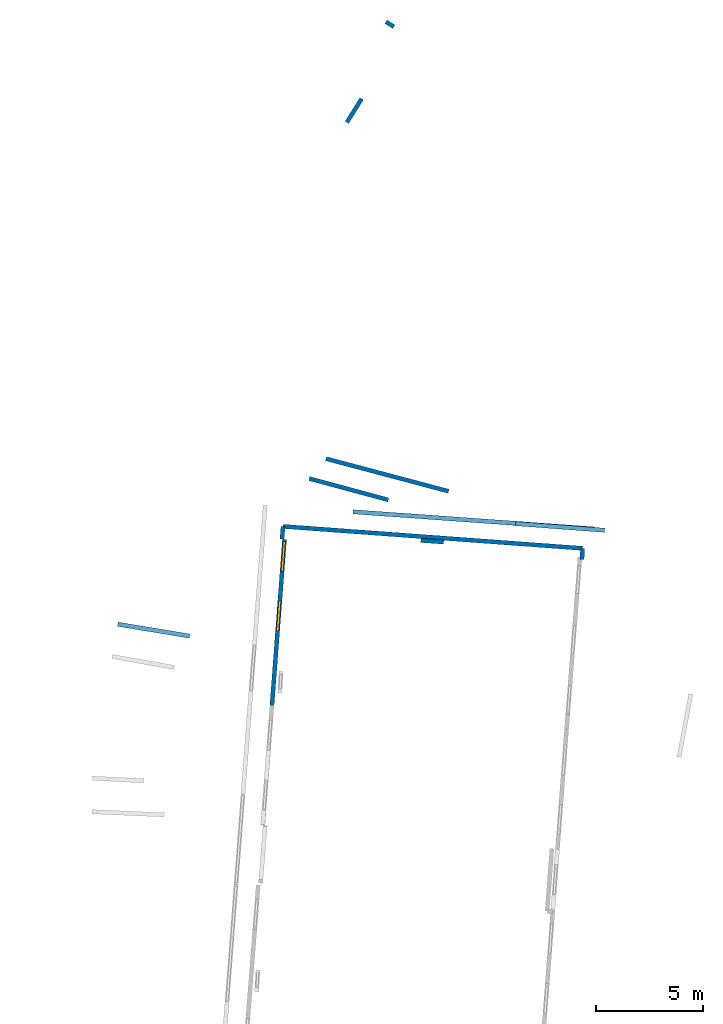
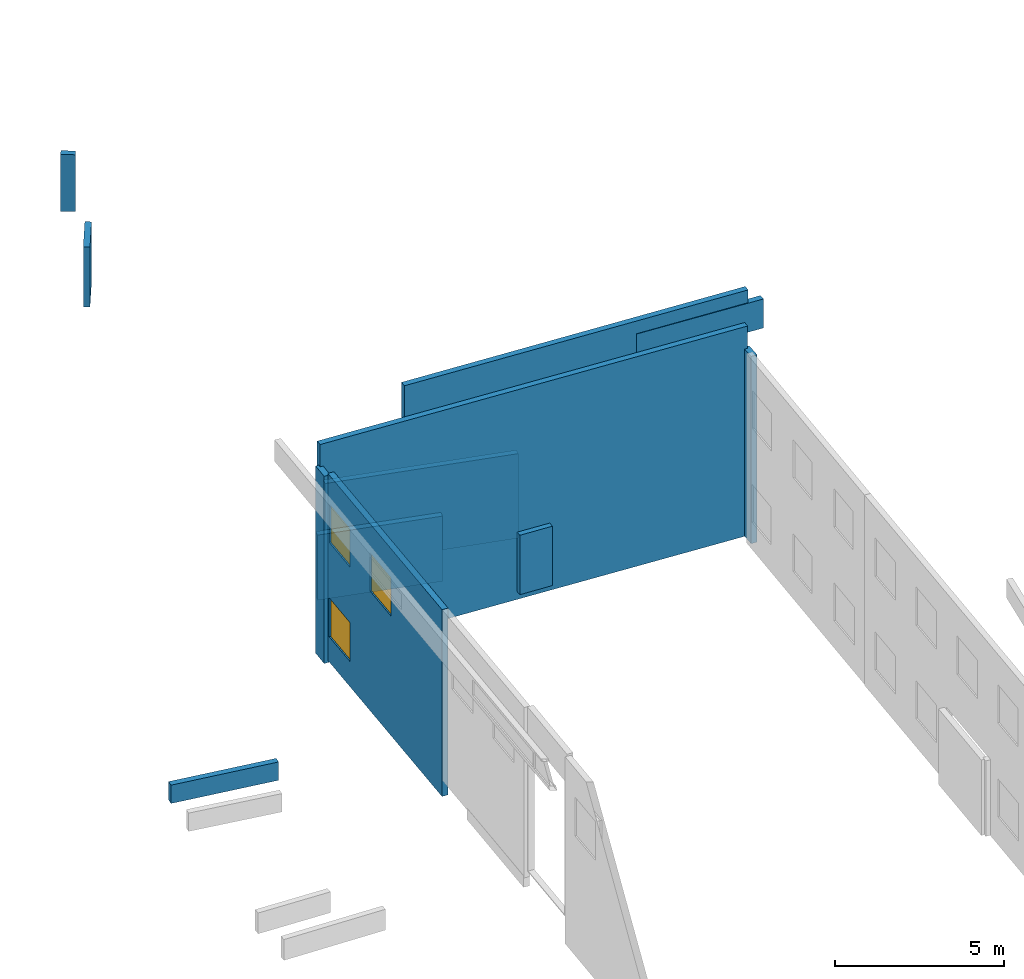
# One storey, part 25 of 27: 12 walls, 3 windows, 3 openings.
"""IFC2X3 building model written with IfcOpenShell, lengths in metres."""

from ifc_helpers import new_model, entity, si_unit, converted_unit, derived_unit, direction, frame, frame_2d, origin, origin_2d_with_axis, place, context, subcontext, project, spatial, polyline, rectangle, outline, extrude, source, transform, mapped, material, layer, layer_set, layer_usage, type_object, type_shapes, element, fill, save


model = new_model("IFC2X3")

# Units and contexts
model_context = context("Model", 3, precision=1e-05, world=origin(), true_north=direction((0.0, 1.0)))
body_context = subcontext(model_context, "Body", "Model", "MODEL_VIEW")
ifc_project = project(units=[si_unit("LENGTHUNIT", "METRE"), si_unit("AREAUNIT", "SQUARE_METRE"), si_unit("VOLUMEUNIT", "CUBIC_METRE"), converted_unit("PLANEANGLEUNIT", "DEGREE", entity("IfcRatioMeasure", 0.0174532925199433), si_unit("PLANEANGLEUNIT", "RADIAN"), dimensions=[0, 0, 0, 0, 0, 0, 0]), si_unit("MASSUNIT", "GRAM", prefix="KILO"), derived_unit("MASSDENSITYUNIT", [(si_unit("MASSUNIT", "GRAM", prefix="KILO"), 1), (si_unit("LENGTHUNIT", "METRE"), -3)]), derived_unit("MOMENTOFINERTIAUNIT", [(si_unit("LENGTHUNIT", "METRE"), 4)]), si_unit("TIMEUNIT", "SECOND"), si_unit("FREQUENCYUNIT", "HERTZ"), si_unit("THERMODYNAMICTEMPERATUREUNIT", "DEGREE_CELSIUS"), derived_unit("THERMALTRANSMITTANCEUNIT", [(si_unit("MASSUNIT", "GRAM", prefix="KILO"), 1), (si_unit("THERMODYNAMICTEMPERATUREUNIT", "KELVIN"), -1), (si_unit("TIMEUNIT", "SECOND"), -3)]), derived_unit("VOLUMETRICFLOWRATEUNIT", [(si_unit("LENGTHUNIT", "METRE"), 3), (si_unit("TIMEUNIT", "SECOND"), -1)]), si_unit("ELECTRICCURRENTUNIT", "AMPERE"), si_unit("ELECTRICVOLTAGEUNIT", "VOLT"), si_unit("POWERUNIT", "WATT"), si_unit("FORCEUNIT", "NEWTON", prefix="KILO"), si_unit("ILLUMINANCEUNIT", "LUX"), si_unit("LUMINOUSFLUXUNIT", "LUMEN"), si_unit("LUMINOUSINTENSITYUNIT", "CANDELA"), derived_unit("USERDEFINED", [(si_unit("MASSUNIT", "GRAM", prefix="KILO"), -1), (si_unit("LENGTHUNIT", "METRE"), -2), (si_unit("TIMEUNIT", "SECOND"), 3), (si_unit("LUMINOUSFLUXUNIT", "LUMEN"), 1)]), derived_unit("LINEARVELOCITYUNIT", [(si_unit("LENGTHUNIT", "METRE"), 1), (si_unit("TIMEUNIT", "SECOND"), -1)]), si_unit("PRESSUREUNIT", "PASCAL"), derived_unit("USERDEFINED", [(si_unit("LENGTHUNIT", "METRE"), -2), (si_unit("MASSUNIT", "GRAM", prefix="KILO"), 1), (si_unit("TIMEUNIT", "SECOND"), -2)]), derived_unit("LINEARFORCEUNIT", [(si_unit("MASSUNIT", "GRAM", prefix="KILO"), 1), (si_unit("LENGTHUNIT", "METRE"), 1), (si_unit("TIMEUNIT", "SECOND"), -2), (si_unit("LENGTHUNIT", "METRE"), -1)]), derived_unit("PLANARFORCEUNIT", [(si_unit("MASSUNIT", "GRAM", prefix="KILO"), 1), (si_unit("LENGTHUNIT", "METRE"), 1), (si_unit("TIMEUNIT", "SECOND"), -2), (si_unit("LENGTHUNIT", "METRE"), -2)])], contexts=[model_context])

# Site, building, storey
placement_1 = place(None, origin())
site = spatial("IfcSite", under=ifc_project, at=placement_1, CompositionType="ELEMENT")
building = spatial("IfcBuilding", under=site, at=placement_1, CompositionType="ELEMENT")
storey_placement = place(placement_1, frame((0.0, 0.0, -61.043098449707)))
storey = spatial("IfcBuildingStorey", under=building, at=storey_placement, Name="level_-61.043098", CompositionType="ELEMENT", Elevation=-61.043098449707)

# Wall
ifc_material_1 = material(Name="Default wall")
ifc_layer = layer(ifc_material_1, 0.2)
ifc_layer_set = layer_set([ifc_layer], Name="wall_thickness_0.2000")
ifc_layer_usage = layer_usage(ifc_layer_set, "AXIS2", "POSITIVE", -0.1)
wall_type = type_object("IfcWallType", Name="wall_thickness_0.2000", PredefinedType="STANDARD", material=ifc_layer_set)
placement_2 = place(placement_1, frame((0.0, 0.0, -54.1657218933105)))
wall_1_placement = place(placement_2, frame((-78.5167072208766, 36.7936952621983, 0.0), z_axis=(0.0, 0.0, 1.0), x_axis=(0.997484238293921, -0.0708886052563871, 0.0)))
element("IfcWallStandardCase", 1, at=wall_1_placement, inside=storey, type_object=wall_type, material=ifc_layer_usage, Name="Wall:413", ObjectType="Wall", context=body_context, shape_type="SweptSolid", body=[
    extrude(outline(polyline([(11.3100008133286, -0.1), (11.3100008133286, 0.1), (0.0, 0.1), (0.0, -0.1), (11.3100008133286, -0.1)])), origin(), (0.0, 0.0, 1.0), 1.25223541259766),
])

# Wall, openings, windows
placement_3 = place(placement_1, frame((0.0, 0.0, -60.9578857421875)))
wall_2_placement = place(placement_3, frame((-81.7229780345346, 35.5088413263071, 0.0), z_axis=(0.0, 0.0, 1.0), x_axis=(-0.075466794937005, -0.997148315378377, 0.0)))
wall_2 = element("IfcWallStandardCase", 2, at=wall_2_placement, inside=storey, type_object=wall_type, material=ifc_layer_usage, Name="Wall:613", ObjectType="Wall", context=body_context, shape_type="SweptSolid", body=[
    extrude(outline(polyline([(7.80127853958035, -0.1), (7.80127853958035, 0.1), (0.0, 0.1), (0.0, -0.1), (7.80127853958035, -0.1)])), origin(), (0.0, 0.0, 1.0), 6.74871063232422),
])
opening_1_placement = place(wall_2_placement, frame((0.0997649139313766, -0.1, 4.31856918334961)))
opening_1 = element("IfcOpeningElement", 3, at=opening_1_placement, cuts=wall_2, Name="Opening : 1400 x 1395 : 45", ObjectType="Opening", context=body_context, shape_type="SweptSolid", body=[
    extrude(rectangle(XDim=1.4, YDim=1.395, at=frame_2d((0.6975, 0.7), x_axis=(0.0, 1.0))), frame((0.0, 0.0, 0.0), z_axis=(0.0, 1.0, 0.0), x_axis=(0.0, 0.0, 1.0)), (0.0, 0.0, 1.0), 0.2),
])
opening_2_placement = place(wall_2_placement, frame((2.89627902610935, -0.1, 4.31856918334961)))
opening_2 = element("IfcOpeningElement", 4, at=opening_2_placement, cuts=wall_2, Name="Opening : 1410 x 1390 : 46", ObjectType="Opening", context=body_context, shape_type="SweptSolid", body=[
    extrude(rectangle(XDim=1.41, YDim=1.39, at=frame_2d((0.695, 0.705), x_axis=(0.0, 1.0))), frame((0.0, 0.0, 0.0), z_axis=(0.0, 1.0, 0.0), x_axis=(0.0, 0.0, 1.0)), (0.0, 0.0, 1.0), 0.2),
])
opening_3_placement = place(wall_2_placement, frame((0.0984717381681843, -0.1, 0.9085693359375)))
opening_3 = element("IfcOpeningElement", 5, at=opening_3_placement, cuts=wall_2, Name="Opening : 1405 x 1405 : 47", ObjectType="Opening", context=body_context, shape_type="SweptSolid", body=[
    extrude(rectangle(XDim=1.405, YDim=1.405, at=frame_2d((0.7025, 0.7025), x_axis=(0.0, 1.0))), frame((0.0, 0.0, 0.0), z_axis=(0.0, 1.0, 0.0), x_axis=(0.0, 0.0, 1.0)), (0.0, 0.0, 1.0), 0.2),
])
ifc_material_2 = material(Name="Window Default")
window_style_1 = type_object("IfcWindowStyle", Name="Window : 1400 x 1395mm", ConstructionType="NOTDEFINED", OperationType="NOTDEFINED", ParameterTakesPrecedence=False, Sizeable=False, material=ifc_material_2)
shared_shape_1 = source(origin(), body_context, "Body", "SweptSolid", [
    extrude(rectangle(XDim=0.1, YDim=1.4, at=origin_2d_with_axis()), frame((0.7, 0.1, 0.0), z_axis=(0.0, 0.0, 1.0), x_axis=(0.0, 1.0, 0.0)), (0.0, 0.0, 1.0), 1.395),
])
type_shapes(window_style_1, [shared_shape_1])
window_1_placement = place(opening_1_placement, origin())
window_1 = element("IfcWindow", 6, at=window_1_placement, inside=storey, type_object=window_style_1, Name="Window : 1400 x 1395mm : 38", ObjectType="Window : 1400 x 1395mm", OverallHeight=1.395, OverallWidth=1.4, context=body_context, shape_type="MappedRepresentation", body=[
    mapped(shared_shape_1, transform((0.0, 0.0, 0.0), scale=1.0)),
])
fill(opening_1, window_1)
window_style_2 = type_object("IfcWindowStyle", Name="Window : 1410 x 1390mm", ConstructionType="NOTDEFINED", OperationType="NOTDEFINED", ParameterTakesPrecedence=False, Sizeable=False, material=ifc_material_2)
shared_shape_2 = source(origin(), body_context, "Body", "SweptSolid", [
    extrude(rectangle(XDim=0.1, YDim=1.41, at=origin_2d_with_axis()), frame((0.705, 0.1, 0.0), z_axis=(0.0, 0.0, 1.0), x_axis=(0.0, 1.0, 0.0)), (0.0, 0.0, 1.0), 1.39),
])
type_shapes(window_style_2, [shared_shape_2])
window_2_placement = place(opening_2_placement, origin())
window_2 = element("IfcWindow", 7, at=window_2_placement, inside=storey, type_object=window_style_2, Name="Window : 1410 x 1390mm : 39", ObjectType="Window : 1410 x 1390mm", OverallHeight=1.39, OverallWidth=1.41, context=body_context, shape_type="MappedRepresentation", body=[
    mapped(shared_shape_2, transform((0.0, 0.0, 0.0), scale=1.0)),
])
fill(opening_2, window_2)
window_style_3 = type_object("IfcWindowStyle", Name="Window : 1405 x 1405mm", ConstructionType="NOTDEFINED", OperationType="NOTDEFINED", ParameterTakesPrecedence=False, Sizeable=False, material=ifc_material_2)
shared_shape_3 = source(origin(), body_context, "Body", "SweptSolid", [
    extrude(rectangle(XDim=0.1, YDim=1.405, at=origin_2d_with_axis()), frame((0.7025, 0.1, 0.0), z_axis=(0.0, 0.0, 1.0), x_axis=(0.0, 1.0, 0.0)), (0.0, 0.0, 1.0), 1.405),
])
type_shapes(window_style_3, [shared_shape_3])
window_3_placement = place(opening_3_placement, origin())
window_3 = element("IfcWindow", 8, at=window_3_placement, inside=storey, type_object=window_style_3, Name="Window : 1405 x 1405mm : 40", ObjectType="Window : 1405 x 1405mm", OverallHeight=1.405, OverallWidth=1.405, context=body_context, shape_type="MappedRepresentation", body=[
    mapped(shared_shape_3, transform((0.0, 0.0, 0.0), scale=1.0)),
])
fill(opening_3, window_3)

# Walls
placement_4 = place(placement_1, frame((0.0, 0.0, -60.9578857421875)))
wall_3_placement = place(placement_4, frame((-89.5221085454093, 31.5337549239329, 0.0), z_axis=(0.0, 0.0, 1.0), x_axis=(0.986684767424187, -0.162644304336423, 0.0)))
element("IfcWallStandardCase", 9, at=wall_3_placement, inside=storey, type_object=wall_type, material=ifc_layer_usage, Name="Wall:657", ObjectType="Wall", context=body_context, shape_type="SweptSolid", body=[
    extrude(outline(polyline([(3.40500332822898, -0.1), (3.40500332822898, 0.1), (0.0, 0.1), (0.0, -0.1), (3.40500332822898, -0.1)])), origin(), (0.0, 0.0, 1.0), 0.661750793457031),
])
wall_4_placement = place(storey_placement, frame((-81.8419514775689, 35.5181316703593, 0.0), z_axis=(0.0, 0.0, 1.0), x_axis=(0.0850277613949976, 0.996378582563955, 0.0)))
element("IfcWallStandardCase", 10, at=wall_4_placement, inside=storey, type_object=wall_type, material=ifc_layer_usage, Name="Wall:781", ObjectType="Wall", context=body_context, shape_type="SweptSolid", body=[
    extrude(outline(polyline([(0.594629291999311, -0.1), (0.594629291999311, 0.1), (0.0, 0.1), (0.0, -0.1), (0.594629291999311, -0.1)])), origin(), (0.0, 0.0, 1.0), 6.76219177246094),
])
placement_5 = place(placement_1, frame((0.0, 0.0, -60.8847198486328)))
wall_5_placement = place(placement_5, frame((-80.5673047351892, 38.3492529555358, 0.0), z_axis=(0.0, 0.0, 1.0), x_axis=(0.965363813396682, -0.260907469774662, 0.0)))
element("IfcWallStandardCase", 11, at=wall_5_placement, inside=storey, type_object=wall_type, material=ifc_layer_usage, Name="Wall:1139", ObjectType="Wall", context=body_context, shape_type="SweptSolid", body=[
    extrude(outline(polyline([(3.82999846030692, -0.1), (3.82999846030692, 0.1), (0.0, 0.1), (0.0, -0.1), (3.82999846030692, -0.1)])), origin(), (0.0, 0.0, 1.0), 2.35505676269531),
])
wall_6_placement = place(storey_placement, frame((-76.9774387916374, 59.714127942678, 0.0), z_axis=(0.0, 0.0, 1.0), x_axis=(0.84592267849121, -0.533305561581967, 0.0)))
element("IfcWallStandardCase", 12, at=wall_6_placement, inside=storey, type_object=wall_type, material=ifc_layer_usage, Name="Wall:1147", ObjectType="Wall", context=body_context, shape_type="SweptSolid", body=[
    extrude(outline(polyline([(0.435005428259214, -0.1), (0.435005428259214, 0.1), (0.0, 0.1), (0.0, -0.1), (0.435005428259214, -0.1)])), origin(), (0.0, 0.0, 1.0), 2.05445098876953),
])
placement_6 = place(placement_1, frame((0.0, 0.0, -61.0783157348633)))
wall_7_placement = place(placement_6, frame((-78.1166234207038, 56.1134086578947, 0.0), z_axis=(0.0, 0.0, 1.0), x_axis=(-0.530829080681293, -0.84747890068311, 0.0)))
element("IfcWallStandardCase", 13, at=wall_7_placement, inside=storey, type_object=wall_type, material=ifc_layer_usage, Name="Wall:1231", ObjectType="Wall", context=body_context, shape_type="SweptSolid", body=[
    extrude(outline(polyline([(1.30444288653706, -0.1), (1.30444288653706, 0.1), (0.0, 0.1), (0.0, -0.1), (1.30444288653706, -0.1)])), origin(), (0.0, 0.0, 1.0), 2.17284774780273),
])
wall_8_placement = place(storey_placement, frame((-67.8099302443536, 34.5569653867136, 0.0), z_axis=(0.0, 0.0, 1.0), x_axis=(0.0566080547137008, 0.998396478430053, 0.0)))
element("IfcWallStandardCase", 14, at=wall_8_placement, inside=storey, type_object=wall_type, material=ifc_layer_usage, Name="Wall:1413", ObjectType="Wall", context=body_context, shape_type="SweptSolid", body=[
    extrude(outline(polyline([(0.52629940730538, -0.1), (0.52629940730538, 0.1), (0.0, 0.1), (0.0, -0.1), (0.52629940730538, -0.1)])), origin(), (0.0, 0.0, 1.0), 6.76219177246094),
])
placement_7 = place(placement_1, frame((0.0, 0.0, -54.4207000732422)))
wall_9_placement = place(placement_7, frame((-70.9075820186473, 36.23885292246, 0.0), z_axis=(0.0, 0.0, 1.0), x_axis=(0.997232858279763, -0.0743412830611191, 0.0)))
element("IfcWallStandardCase", 15, at=wall_9_placement, inside=storey, type_object=wall_type, material=ifc_layer_usage, Name="Wall:1460", ObjectType="Wall", context=body_context, shape_type="SweptSolid", body=[
    extrude(outline(polyline([(4.16869326299612, -0.1), (4.16869326299612, 0.1), (0.0, 0.1), (0.0, -0.1), (4.16869326299612, -0.1)])), origin(), (0.0, 0.0, 1.0), 1.04800796508789),
])
placement_8 = place(placement_1, frame((0.0, 0.0, -60.7575225830078)))
wall_10_placement = place(placement_8, frame((-74.2764587462608, 35.3811552395618, 0.0), z_axis=(0.0, 0.0, 1.0), x_axis=(-0.997712741281981, 0.067596493130888, 0.0)))
element("IfcWallStandardCase", 16, at=wall_10_placement, inside=storey, type_object=wall_type, material=ifc_layer_usage, Name="Wall:1534", ObjectType="Wall", context=body_context, shape_type="SweptSolid", body=[
    extrude(outline(polyline([(1.07499908423039, -0.1), (1.07499908423039, 0.1), (0.0, 0.1), (0.0, -0.1), (1.07499908423039, -0.1)])), origin(), (0.0, 0.0, 1.0), 2.14541244506836),
])
wall_11_placement = place(storey_placement, frame((-81.791391469438, 36.1106067611526, 0.0), z_axis=(0.0, 0.0, 1.0), x_axis=(0.99731830182013, -0.0731860974134502, 0.0)))
element("IfcWallStandardCase", 17, at=wall_11_placement, inside=storey, type_object=wall_type, material=ifc_layer_usage, Name="Wall:1594", ObjectType="Wall", context=body_context, shape_type="SweptSolid", body=[
    extrude(outline(polyline([(14.0489359924081, -0.1), (14.0489359924081, 0.1), (0.0, 0.1), (0.0, -0.1), (14.0489359924081, -0.1)])), origin(), (0.0, 0.0, 1.0), 7.56739807128906),
])
placement_9 = place(placement_1, frame((0.0, 0.0, -60.5600128173828)))
wall_12_placement = place(placement_9, frame((-79.7783962396944, 39.2759120709602, 0.0), z_axis=(0.0, 0.0, 1.0), x_axis=(0.966441881841275, -0.256885361636461, 0.0)))
element("IfcWallStandardCase", 18, at=wall_12_placement, inside=storey, type_object=wall_type, material=ifc_layer_usage, Name="Wall:1691", ObjectType="Wall", context=body_context, shape_type="SweptSolid", body=[
    extrude(outline(polyline([(5.92499753898789, -0.1), (5.92499753898789, 0.1), (0.0, 0.1), (0.0, -0.1), (5.92499753898789, -0.1)])), origin(), (0.0, 0.0, 1.0), 3.05535125732422),
])

save(model, "model.ifc")
